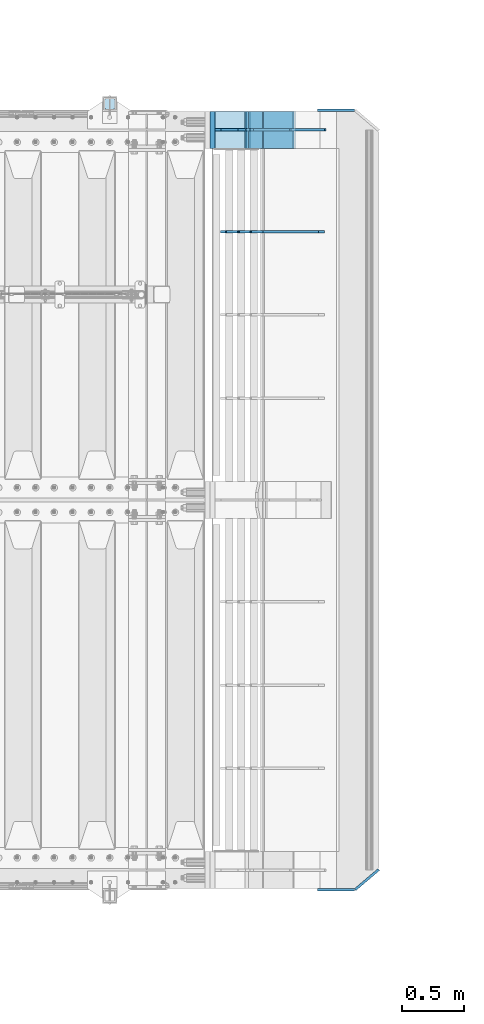
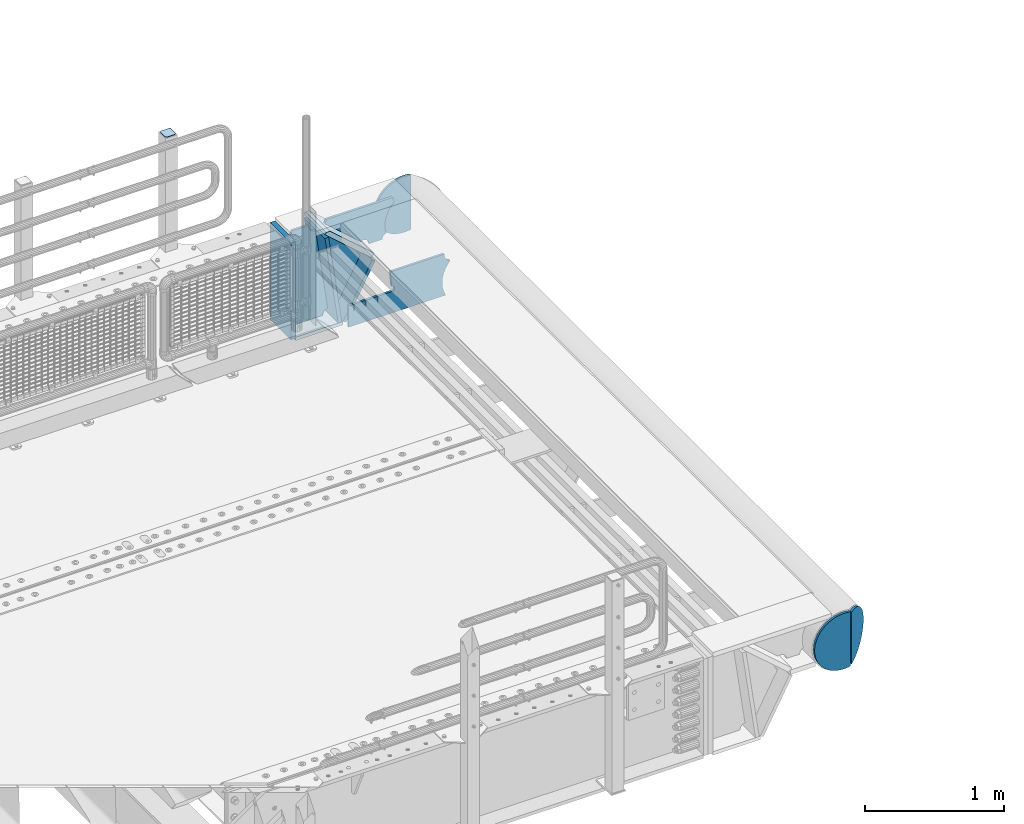
# One storey, part 180 of 193: 13 plates.
"""IFC2X3 building model written with IfcOpenShell, lengths in millimetres."""

from ifc_helpers import new_model, si_unit, frame, origin_with_axes, place, context, subcontext, project, spatial, faceted_brep, material, type_object, element, save


model = new_model("IFC2X3")

# Units and contexts
model_context = context("Model", 3, precision=1e-05, world=origin_with_axes())
body_context = subcontext(model_context, "Body", "Model", "MODEL_VIEW")
ifc_project = project(units=[si_unit("LENGTHUNIT", "METRE", prefix="MILLI"), si_unit("AREAUNIT", "SQUARE_METRE"), si_unit("VOLUMEUNIT", "CUBIC_METRE"), si_unit("MASSUNIT", "GRAM", prefix="KILO"), si_unit("TIMEUNIT", "SECOND"), si_unit("PLANEANGLEUNIT", "RADIAN"), si_unit("SOLIDANGLEUNIT", "STERADIAN"), si_unit("THERMODYNAMICTEMPERATUREUNIT", "DEGREE_CELSIUS"), si_unit("LUMINOUSINTENSITYUNIT", "LUMEN")], contexts=[model_context])

# Site, building, storey
site_placement = place(None, origin_with_axes())
site = spatial("IfcSite", under=ifc_project, at=site_placement, CompositionType="ELEMENT")
building_placement = place(site_placement, origin_with_axes())
building = spatial("IfcBuilding", under=site, at=building_placement, Name="Standard", CompositionType="ELEMENT")
storey_placement = place(building_placement, origin_with_axes())
storey = spatial("IfcBuildingStorey", under=building, at=storey_placement, Name="Undefined", CompositionType="ELEMENT", Elevation=0.0)

# Plates
ifc_material_1 = material(Name="STEEL/S355J2")
plate_type_1 = type_object("IfcPlateType", PredefinedType="NOTDEFINED")
plate_1_placement = place(storey_placement, frame((-29150.9999999999, 30166.0000000002, 1012.50000000001), z_axis=(0.0, 1.0, 0.0), x_axis=(-1.0, 0.0, 0.0)))
element("IfcPlate", 1, at=plate_1_placement, inside=storey, type_object=plate_type_1, material=ifc_material_1, context=body_context, shape_type="Brep", body=[
    faceted_brep([(0.0, -2.5, 19.0), (0.0, -2.5, 69.0), (0.0, 2.5, 69.0), (0.0, 2.5, 19.0), (0.476369668544066, -2.5, 73.2278977451715), (0.476369668544066, 2.5, 73.2278977451715), (1.88159150985302, -2.5, 77.2437910432345), (1.88159150985302, 2.5, 77.2437910432345), (4.14520183310742, -2.5, 80.8463062353148), (4.14520183310742, 2.5, 80.8463062353148), (7.15369376468516, -2.5, 83.8547981668926), (7.15369376468516, 2.5, 83.8547981668926), (10.7562089567655, -2.5, 86.118408490147), (10.7562089567655, 2.5, 86.118408490147), (14.7721022548285, -2.5, 87.5236303314559), (14.7721022548285, 2.5, 87.5236303314559), (19.0, -2.5, 88.0), (19.0, 2.5, 88.0), (69.0, -2.5, 88.0), (69.0, 2.5, 88.0), (73.2278977451715, -2.5, 87.5236303314559), (73.2278977451715, 2.5, 87.5236303314559), (77.2437910432345, -2.5, 86.118408490147), (77.2437910432345, 2.5, 86.118408490147), (80.8463062353148, -2.5, 83.8547981668926), (80.8463062353148, 2.5, 83.8547981668926), (83.8547981668926, -2.5, 80.8463062353148), (83.8547981668926, 2.5, 80.8463062353148), (86.118408490147, -2.5, 77.2437910432345), (86.118408490147, 2.5, 77.2437910432345), (87.5236303314559, -2.5, 73.2278977451715), (87.5236303314559, 2.5, 73.2278977451715), (88.0, -2.5, 69.0), (88.0, 2.5, 69.0), (88.0, -2.5, 19.0), (88.0, 2.5, 19.0), (87.5236303314559, -2.5, 14.7721022548285), (87.5236303314559, 2.5, 14.7721022548285), (86.118408490147, -2.5, 10.7562089567655), (86.118408490147, 2.5, 10.7562089567655), (83.8547981668926, -2.5, 7.15369376468516), (83.8547981668926, 2.5, 7.15369376468516), (80.8463062353148, -2.5, 4.14520183310742), (80.8463062353148, 2.5, 4.14520183310742), (77.2437910432345, -2.5, 1.88159150985302), (77.2437910432345, 2.5, 1.88159150985302), (73.2278977451715, -2.5, 0.476369668544066), (73.2278977451715, 2.5, 0.476369668544066), (69.0, -2.5, 0.0), (69.0, 2.5, 0.0), (19.0, -2.5, 0.0), (19.0, 2.5, 0.0), (14.7721022548285, -2.5, 0.476369668544066), (14.7721022548285, 2.5, 0.476369668544066), (10.7562089567655, -2.5, 1.88159150985302), (10.7562089567655, 2.5, 1.88159150985302), (7.15369376468516, -2.5, 4.14520183310742), (7.15369376468516, 2.5, 4.14520183310742), (4.14520183310742, -2.5, 7.15369376468516), (4.14520183310742, 2.5, 7.15369376468516), (1.88159150985302, -2.5, 10.7562089567655), (1.88159150985302, 2.5, 10.7562089567655), (0.476369668544066, -2.5, 14.7721022548285), (0.476369668544066, 2.5, 14.7721022548285)], [[[0, 1, 2, 3]], [[1, 4, 5, 2]], [[4, 6, 7, 5]], [[6, 8, 9, 7]], [[8, 10, 11, 9]], [[10, 12, 13, 11]], [[12, 14, 15, 13]], [[14, 16, 17, 15]], [[16, 18, 19, 17]], [[18, 20, 21, 19]], [[20, 22, 23, 21]], [[22, 24, 25, 23]], [[24, 26, 27, 25]], [[26, 28, 29, 27]], [[28, 30, 31, 29]], [[30, 32, 33, 31]], [[32, 34, 35, 33]], [[34, 36, 37, 35]], [[36, 38, 39, 37]], [[38, 40, 41, 39]], [[40, 42, 43, 41]], [[42, 44, 45, 43]], [[44, 46, 47, 45]], [[46, 48, 49, 47]], [[48, 50, 51, 49]], [[50, 52, 53, 51]], [[52, 54, 55, 53]], [[54, 56, 57, 55]], [[56, 58, 59, 57]], [[58, 60, 61, 59]], [[60, 62, 63, 61]], [[62, 0, 3, 63]], [[5, 7, 9, 11, 13, 15, 17, 19, 21, 23, 25, 27, 29, 31, 33, 35, 37, 39, 41, 43, 45, 47, 49, 51, 53, 55, 57, 59, 61, 63, 3, 2]], [[62, 60, 58, 56, 54, 52, 50, 48, 46, 44, 42, 40, 38, 36, 34, 32, 30, 28, 26, 24, 22, 20, 18, 16, 14, 12, 10, 8, 6, 4, 1, 0]]]),
])
ifc_material_2 = material(Name="STEEL/S355N")
plate_type_2 = type_object("IfcPlateType", PredefinedType="NOTDEFINED")
plate_2_placement = place(storey_placement, frame((-27701.0011701102, 30149.9999999992, -367.999999999302), z_axis=(-0.752989422949573, 0.0, 0.658032619955933), x_axis=(0.0, -1.0, 0.0)))
element("IfcPlate", 2, at=plate_2_placement, inside=storey, type_object=plate_type_2, material=ifc_material_2, context=body_context, shape_type="Brep", body=[
    faceted_brep([(-8.11269273981452e-10, 20.0, 490.766265601622), (0.0, -0.30381125094209, 514.0), (300.0, -0.30381125094209, 514.0), (300.0, 20.0, 490.766265601622), (300.0, -20.0, 0.0), (300.0, -20.0, 514.000000000004), (0.0, -20.0, 514.000000000004), (0.0, -20.0, 0.0), (0.0, 20.0, 0.0), (300.0, 20.0, 0.0)], [[[0, 1, 2, 3]], [[4, 5, 6, 7]], [[4, 7, 8, 9]], [[9, 8, 0, 3]], [[5, 4, 9, 3, 2]], [[6, 5, 2, 1]], [[8, 7, 6, 1, 0]]]),
])
ifc_material_3 = material()
plate_3_placement = place(storey_placement, frame((-28363.0011701094, 30150.0, -870.000000000003), z_axis=(0.0, 0.0, 1.0), x_axis=(0.0, -1.0, 0.0)))
element("IfcPlate", 3, at=plate_3_placement, inside=storey, type_object=plate_type_2, material=ifc_material_3, context=body_context, shape_type="Brep", body=[
    faceted_brep([(0.0, -20.0, 0.0), (0.0, -20.0, 850.0), (0.0, 20.0, 850.0), (0.0, 20.0, 0.0), (300.0, -20.0, 850.0), (300.0, 20.0, 850.0), (300.0, -20.0, 0.0), (300.0, 20.0, 0.0)], [[[0, 1, 2, 3]], [[1, 4, 5, 2]], [[4, 6, 7, 5]], [[6, 0, 3, 7]], [[5, 7, 3, 2]], [[6, 4, 1, 0]]]),
])
plate_type_3 = type_object("IfcPlateType", PredefinedType="NOTDEFINED")
plate_4_placement = place(storey_placement, frame((-27950.0011701109, 30150.0, -875.000000003253), z_axis=(0.0, -1.0, 0.0), x_axis=(-1.0, 0.0, 0.0)))
element("IfcPlate", 4, at=plate_4_placement, inside=storey, type_object=plate_type_3, material=ifc_material_2, context=body_context, shape_type="Brep", body=[
    faceted_brep([(0.0, -15.0, 0.0), (0.0, -15.0, 300.0), (0.0, 15.0, 300.0), (0.0, 15.0, 0.0), (393.0, -15.0, 300.0), (393.0, 15.0, 300.0), (393.0, -15.0, 0.0), (393.0, 15.0, 0.0)], [[[0, 1, 2, 3]], [[1, 4, 5, 2]], [[4, 6, 7, 5]], [[6, 0, 3, 7]], [[5, 7, 3, 2]], [[6, 4, 1, 0]]]),
])
plate_5_placement = place(storey_placement, frame((-27973.8519322781, 30150.000000001, -862.083788721732), z_axis=(-0.139173011053008, 0.0, 0.990268081377179), x_axis=(0.0, -1.0, 0.0)))
element("IfcPlate", 5, at=plate_5_placement, inside=storey, type_object=plate_type_3, material=ifc_material_2, context=body_context, shape_type="Brep", body=[
    faceted_brep([(1.00408215075731e-09, 14.9994702460535, -0.00376939767284057), (300.0, 15.0, 0.0), (300.0, -15.0, 4.21237841386892), (0.0, -15.0, 4.21237841386892), (0.0, -15.0, 792.0), (300.0, -15.0, 792.0), (300.0, 14.9999999999964, 792.0), (0.0, 14.9999999999964, 792.0)], [[[0, 1, 2, 3]], [[4, 5, 6, 7]], [[4, 7, 0, 3]], [[5, 4, 3, 2]], [[6, 5, 2, 1]], [[7, 6, 1, 0]]]),
])
plate_6_placement = place(storey_placement, frame((-27936.7531990434, 30150.000000001, -867.038754739308), z_axis=(0.469471552246176, 0.0, 0.882947598462992), x_axis=(0.0, -1.0, 0.0)))
element("IfcPlate", 6, at=plate_6_placement, inside=storey, type_object=plate_type_3, material=ifc_material_2, context=body_context, shape_type="Brep", body=[
    faceted_brep([(0.0, -15.0, 0.0), (0.0, -15.0000000000036, 514.999999999996), (0.0, 14.9999999999964, 514.999999999998), (0.0, 15.0, 0.0), (300.0, -15.0000000000036, 514.999999999996), (300.0, 14.9999999999964, 514.999999999998), (300.0, -15.0, 0.0), (300.0, 15.0, 0.0)], [[[0, 1, 2, 3]], [[1, 4, 5, 2]], [[4, 6, 7, 5]], [[6, 0, 3, 7]], [[5, 7, 3, 2]], [[6, 4, 1, 0]]]),
])
plate_type_4 = type_object("IfcPlateType", PredefinedType="NOTDEFINED")
plate_7_placement = place(storey_placement, frame((-27386.0011701102, 29999.9999999994, -29.9999999993023), z_axis=(-0.000446694000102124, 0.0, -0.99999990023223), x_axis=(-0.99999990023223, 0.0, 0.000446694000103734)))
element("IfcPlate", 7, at=plate_7_placement, inside=storey, type_object=plate_type_4, material=ifc_material_2, context=body_context, shape_type="Brep", body=[
    faceted_brep([(125.007775472983, 10.0, 291.842314882031), (131.755016800053, 10.0, 263.793234614468), (131.755016800053, -10.0, 263.793234614468), (125.007775472983, -10.0, 291.842314882031), (134.899927074483, 10.0, 224.060281342732), (134.899927074483, -10.0, 224.060281342732), (131.79051499522, 10.0, 184.324534302446), (131.79051499522, -10.0, 184.324534302446), (122.503344607208, 10.0, 145.564419461128), (122.503344607208, -10.0, 145.564419461128), (107.267096867745, 10.0, 108.734339483615), (107.267096867745, -10.0, 108.734339483615), (86.4569387623887, 10.0, 74.7411731709829), (86.4569387623887, -10.0, 74.7411731709829), (60.5852854486511, 10.0, 44.4219450946983), (60.5852854486511, -10.0, 44.4219450946983), (56.2519855253086, 10.0, 40.7176084148888), (56.2519855253086, -10.0, 40.7176084148888), (136.409234539125, -10.0, 297.721677540594), (147.386991180581, -10.0, 308.778803581017), (147.386991180581, 10.0, 308.778803581017), (136.409234539125, 10.0, 297.721677540594), (154.428166132755, -10.0, 322.678193223937), (154.428166132755, 10.0, 322.678193223937), (156.849001662977, -10.0, 338.070097995228), (156.849001662977, 10.0, 338.070097995228), (264.849004013293, -10.0, 338.118348049693), (264.849004013293, 10.0, 338.118348049693), (267.62876711955, -10.0, 321.701412969031), (267.62876711955, 10.0, 321.701412969031), (275.645118712178, -10.0, 307.107546191754), (275.645118712178, 10.0, 307.107546191754), (288.009068357209, -10.0, 295.955165748785), (288.009068357209, 10.0, 295.955165748785), (303.34948944753, -10.0, 289.481038692482), (303.34948944753, 10.0, 289.481038692482), (319.965173216926, -10.0, 288.403127172445), (319.965173216926, 10.0, 288.403127172445), (336.013487920231, -10.0, 292.840968489265), (336.013487920231, 10.0, 292.840968489265), (335.869079589844, -10.0, 293.150054931641), (335.869079589844, 10.0, 293.150054931641), (633.937057436444, -10.0, 32.8861672876965), (633.937057436444, 10.0, 32.8861672876965), (628.672097726401, -10.0, 25.6357574923157), (628.672097726401, 10.0, 25.6357574923157), (624.785781531271, -10.0, 17.5620477266102), (624.785781531271, 10.0, 17.5620477266102), (622.402919050601, -10.0, 8.92432757904926), (622.402919050601, 10.0, 8.92432757904926), (621.600036621097, -10.0, -8.74671002293326e-10), (621.600036621097, 10.0, -8.74671002293326e-10), (70.0, -10.0, -9.84954340310651e-11), (70.0, 10.0, -9.84954340310651e-11), (67.7728137216618, -10.0, 17.5170123094482), (67.7728137216618, 10.0, 17.5170123094482), (61.2329794213983, -10.0, 33.9193489203215), (61.2329794213983, 10.0, 33.9193489203215)], [[[0, 1, 2, 3]], [[4, 5, 2, 1]], [[6, 7, 5, 4]], [[8, 9, 7, 6]], [[10, 11, 9, 8]], [[12, 13, 11, 10]], [[14, 15, 13, 12]], [[16, 17, 15, 14]], [[18, 19, 20, 21]], [[19, 22, 23, 20]], [[22, 24, 25, 23]], [[24, 26, 27, 25]], [[26, 28, 29, 27]], [[28, 30, 31, 29]], [[30, 32, 33, 31]], [[32, 34, 35, 33]], [[34, 36, 37, 35]], [[36, 38, 39, 37]], [[38, 40, 41, 39]], [[40, 42, 43, 41]], [[42, 44, 45, 43]], [[44, 46, 47, 45]], [[46, 48, 49, 47]], [[48, 50, 51, 49]], [[50, 52, 53, 51]], [[52, 54, 55, 53]], [[54, 56, 57, 55]], [[12, 10, 8, 6, 4, 1, 0, 21, 20, 23, 25, 27, 29, 31, 33, 35, 37, 39, 41, 43, 45, 47, 49, 51, 53, 55, 57, 16, 14]], [[18, 21, 0, 3]], [[56, 54, 52, 50, 48, 46, 44, 42, 40, 38, 36, 34, 32, 30, 28, 26, 24, 22, 19, 18, 3, 2, 5, 7, 9, 11, 13, 15, 17]], [[57, 56, 17, 16]]]),
])
plate_type_5 = type_object("IfcPlateType", PredefinedType="NOTDEFINED")
plate_8_placement = place(storey_placement, frame((-27701.9974314966, 30000.000000001, -393.996688204407), z_axis=(-0.658066357015091, 0.0, -0.752959939017267), x_axis=(-0.752959939017268, 0.0, 0.65806635701509)))
element("IfcPlate", 8, at=plate_8_placement, inside=storey, type_object=plate_type_5, material=ifc_material_2, context=body_context, shape_type="Brep", body=[
    faceted_brep([(-11.3595226159632, -10.0, 48.6925173505915), (-112.015767301036, -10.0, 480.154833723627), (-112.015767301036, 10.0, 480.154833723627), (-11.3595226159632, 10.0, 48.6925173505915), (-104.567323293642, -10.0, 482.519601382541), (-104.567323293642, 10.0, 482.519601382541), (-97.5783311599989, -10.0, 486.016090073754), (-97.5783311599989, 10.0, 486.016090073754), (-91.2195220373869, -10.0, 490.558885551654), (-91.2195220373869, 10.0, 490.558885551654), (-85.6462325884277, -10.0, 496.037013784004), (-85.6462325884277, 10.0, 496.037013784004), (447.024482710491, -10.0, 32.810337289633), (447.024482710491, 10.0, 32.810337289633), (441.786973010392, -10.0, 25.5709623937255), (441.786973010392, 10.0, 25.5709623937255), (437.921644570128, -10.0, 17.5149526624118), (437.921644570128, 10.0, 17.5149526624118), (435.551940606492, -10.0, 8.89958500531793), (435.551940606492, 10.0, 8.89958500531793), (434.753540039059, -10.0, -5.20230969414115e-10), (434.753540039059, 10.0, -5.20230969414115e-10), (50.0, -10.0, 0.0), (50.0, 10.0, 0.0), (47.7668538974212, -10.0, 14.7759151575156), (47.7668538974212, 10.0, 14.7759151575156), (41.2668932502784, -10.0, 28.2319592212407), (41.2668932502784, 10.0, 28.2319592212407), (31.0807325300157, -10.0, 39.1661596968261), (31.0807325300157, 10.0, 39.1661596968261), (18.1182591411452, -10.0, 46.6018098971945), (18.1182591411452, 10.0, 46.6018098971945), (3.53735696080548, -10.0, 49.8747140917294), (3.53735696080548, 10.0, 49.8747140917294)], [[[0, 1, 2, 3]], [[1, 4, 5, 2]], [[4, 6, 7, 5]], [[6, 8, 9, 7]], [[8, 10, 11, 9]], [[10, 12, 13, 11]], [[12, 14, 15, 13]], [[14, 16, 17, 15]], [[16, 18, 19, 17]], [[18, 20, 21, 19]], [[20, 22, 23, 21]], [[22, 24, 25, 23]], [[24, 26, 27, 25]], [[26, 28, 29, 27]], [[28, 30, 31, 29]], [[30, 32, 33, 31]], [[32, 0, 3, 33]], [[5, 7, 9, 11, 13, 15, 17, 19, 21, 23, 25, 27, 29, 31, 33, 3, 2]], [[32, 30, 28, 26, 24, 22, 20, 18, 16, 14, 12, 10, 8, 6, 4, 1, 0]]]),
])
plate_type_6 = type_object("IfcPlateType", PredefinedType="NOTDEFINED")
plate_9_placement = place(storey_placement, frame((-28104.001170111, 30000.0, -30.0000000032531), z_axis=(0.0, 0.0, -1.0), x_axis=(-1.0, 0.0, 0.0)))
element("IfcPlate", 9, at=plate_9_placement, inside=storey, type_object=plate_type_6, material=ifc_material_2, context=body_context, shape_type="Brep", body=[
    faceted_brep([(-9.00602409638668, -10.0, 65.0), (-108.137843376921, -10.0, 780.473130459514), (-108.137843376921, 10.0, 780.473130459514), (-9.00602409638668, 10.0, 65.0), (-94.4157884488377, -10.0, 784.433672138112), (-94.4157884488377, 10.0, 784.433672138112), (-82.3732461236723, -10.0, 792.112074067144), (-82.3732461236723, 10.0, 792.112074067144), (-72.9927947992364, -10.0, 802.881837982249), (-72.9927947992364, 10.0, 802.881837982249), (-67.0398068183713, -10.0, 815.864234368775), (-67.0398068183713, 10.0, 815.864234368775), (-65.0, -10.0, 830.0), (-65.0, 10.0, 830.0), (189.0, -10.0, 830.0), (189.0, 10.0, 830.0), (191.447174185243, -10.0, 814.549150281253), (191.447174185243, 10.0, 814.549150281253), (198.549150281251, -10.0, 800.610737385376), (198.549150281251, 10.0, 800.610737385376), (209.610737385377, -10.0, 789.549150281253), (209.610737385377, 10.0, 789.549150281253), (223.549150281251, -10.0, 782.447174185242), (223.549150281251, 10.0, 782.447174185242), (239.0, -10.0, 780.0), (239.0, 10.0, 780.0), (239.0, -10.0, 50.0), (239.0, 10.0, 50.0), (223.549150281251, -10.0, 47.5528258147577), (223.549150281251, 10.0, 47.5528258147577), (209.610737385377, -10.0, 40.4508497187474), (209.610737385377, 10.0, 40.4508497187474), (198.549150281251, -10.0, 29.3892626146237), (198.549150281251, 10.0, 29.3892626146237), (191.447174185243, -10.0, 15.4508497187474), (191.447174185243, 10.0, 15.4508497187474), (189.0, -10.0, 0.0), (189.0, 10.0, 0.0), (50.4776502774184, -10.0, 0.0), (50.4776502774184, 10.0, 0.0), (47.3830020671812, -10.0, 22.3352870825933), (47.3830020671812, 10.0, 22.3352870825933), (42.8384615202776, -10.0, 37.3040735979326), (42.8384615202776, 10.0, 37.3040735979326), (33.8907372011709, -10.0, 50.1358952937587), (33.8907372011709, 10.0, 50.1358952937587), (21.4156947086703, -10.0, 59.5746840579253), (21.4156947086703, 10.0, 59.5746840579253), (6.63447812067898, -10.0, 64.6965054822873), (6.63447812067898, 10.0, 64.6965054822873)], [[[0, 1, 2, 3]], [[1, 4, 5, 2]], [[4, 6, 7, 5]], [[6, 8, 9, 7]], [[8, 10, 11, 9]], [[10, 12, 13, 11]], [[12, 14, 15, 13]], [[14, 16, 17, 15]], [[16, 18, 19, 17]], [[18, 20, 21, 19]], [[20, 22, 23, 21]], [[22, 24, 25, 23]], [[24, 26, 27, 25]], [[26, 28, 29, 27]], [[28, 30, 31, 29]], [[30, 32, 33, 31]], [[32, 34, 35, 33]], [[34, 36, 37, 35]], [[36, 38, 39, 37]], [[38, 40, 41, 39]], [[40, 42, 43, 41]], [[42, 44, 45, 43]], [[44, 46, 47, 45]], [[46, 48, 49, 47]], [[48, 0, 3, 49]], [[5, 7, 9, 11, 13, 15, 17, 19, 21, 23, 25, 27, 29, 31, 33, 35, 37, 39, 41, 43, 45, 47, 49, 3, 2]], [[48, 46, 44, 42, 40, 38, 36, 34, 32, 30, 28, 26, 24, 22, 20, 18, 16, 14, 12, 10, 8, 6, 4, 1, 0]]]),
])
plate_type_7 = type_object("IfcPlateType", PredefinedType="NOTDEFINED")
plate_10_placement = place(storey_placement, frame((-27457.0817660324, 29174.9992828369, -374.002067436516), z_axis=(0.0, 0.0, 1.0), x_axis=(-1.0, 0.0, 0.0)))
element("IfcPlate", 10, at=plate_10_placement, inside=storey, type_object=plate_type_7, material=ifc_material_2, context=body_context, shape_type="Brep", body=[
    faceted_brep([(801.919404066546, -10.0, 188.0), (801.919404066546, 10.0, 188.0), (801.919404066546, 10.0, 132.002067436952), (801.919404066546, -10.0, 132.002067436952), (793.919404066546, 10.0, 132.002067436952), (793.919404066546, -10.0, 132.002067436952), (793.919404066546, 10.0, 180.002067436952), (793.919404066546, -10.0, 180.002067436952), (793.527856196906, 10.0, 182.474203391951), (793.527856196906, -10.0, 182.474203391951), (792.391540021545, 10.0, 184.704349455291), (792.391540021545, -10.0, 184.704349455291), (790.621686084887, 10.0, 186.474203391951), (790.621686084887, -10.0, 186.474203391951), (788.391540021545, 10.0, 187.610519567313), (788.391540021545, -10.0, 187.610519567313), (785.919404066546, -10.0, 188.002067436952), (785.919404066546, 10.0, 188.0), (841.0, -10.0, 188.0), (841.0, -10.0, 0.0), (841.0, 10.0, 0.0), (841.0, 10.0, 188.0), (33.3619566736015, -10.0, 0.0), (33.3619566736015, 10.0, 0.0), (36.2350612208174, -10.0, 4.68848050267007), (36.2350612208174, 10.0, 4.68848050267007), (51.4877592159428, -10.0, 41.5117508652783), (51.4877592159428, 10.0, 41.5117508652783), (60.792242588137, -10.0, 80.2677133162963), (60.792242588137, 10.0, 80.2677133162963), (63.9194040769726, -10.0, 120.002067436515), (63.9194040769726, 10.0, 120.002067436515), (60.792242588137, -10.0, 159.736421556734), (60.792242588137, 10.0, 159.736421556734), (51.4877592159428, -10.0, 198.492384007752), (51.4877592159428, 10.0, 198.492384007752), (36.2350612208174, -10.0, 235.31565437036), (36.2350612208174, 10.0, 235.31565437036), (15.4097206482074, -10.0, 269.299521518803), (15.4097206482074, 10.0, 269.299521518803), (-3.35474438098754, -10.0, 291.269887256574), (-3.35474438098754, 10.0, 291.269887256574), (-2.36881039375294, -10.0, 291.426043859339), (-2.36881039375294, 10.0, 291.426043859339), (17.1449676604716, -10.0, 301.368810393754), (17.1449676604716, 10.0, 301.368810393754), (32.6311896062471, -10.0, 316.855032339527), (32.6311896062471, 10.0, 316.855032339527), (42.573956140659, -10.0, 336.368810393754), (42.573956140659, 10.0, 336.368810393754), (46.0, -10.0, 358.0), (46.0, 10.0, 358.0), (45.0495205499137, -10.0, 364.001091067617), (45.0495205499137, 10.0, 364.001091067617), (495.040008544922, -10.0, 364.010009765625), (495.040008544922, 10.0, 364.010009765625), (483.600036621094, -10.0, 233.759994506836), (483.600036621094, 10.0, 233.759994506836), (472.0, -10.0, 233.759994506836), (472.0, 10.0, 233.759994506836), (468.909830056251, -10.0, 233.270559669787), (468.909830056251, 10.0, 233.270559669787), (466.122147477075, -10.0, 231.850164450585), (466.122147477075, 10.0, 231.850164450585), (463.909830056251, -10.0, 229.637847029761), (463.909830056251, 10.0, 229.637847029761), (462.489434837047, -10.0, 226.850164450585), (462.489434837047, 10.0, 226.850164450585), (462.0, -10.0, 223.759994506836), (462.0, 10.0, 223.759994506836), (462.0, -10.0, 198.0), (462.0, 10.0, 198.0), (462.489434837047, -10.0, 194.909830056251), (462.489434837047, 10.0, 194.909830056251), (463.909830056251, -10.0, 192.122147477075), (463.909830056251, 10.0, 192.122147477075), (466.122147477075, -10.0, 189.909830056251), (466.122147477075, 10.0, 189.909830056251), (468.909830056251, -10.0, 188.489434837048), (468.909830056251, 10.0, 188.489434837048), (472.0, -10.0, 188.0), (472.0, 10.0, 188.0), (585.919404066546, -10.0, 188.002067436952), (585.919404066546, 10.0, 188.0), (588.391540021545, -10.0, 187.610519567313), (588.391540021545, 10.0, 187.610519567313), (590.621686084887, -10.0, 186.474203391951), (590.621686084887, 10.0, 186.474203391951), (592.391540021545, -10.0, 184.704349455291), (592.391540021545, 10.0, 184.704349455291), (593.527856196906, -10.0, 182.474203391951), (593.527856196906, 10.0, 182.474203391951), (593.919404066546, -10.0, 180.002067436952), (593.919404066546, 10.0, 180.002067436952), (593.919404066546, -10.0, 132.002067436952), (593.919404066546, 10.0, 132.002067436952), (601.919404066546, -10.0, 132.002067436952), (601.919404066546, 10.0, 132.002067436952), (601.919404066546, -10.0, 188.0), (601.919404066546, 10.0, 188.0), (685.919404066546, -10.0, 188.002067436952), (685.919404066546, 10.0, 188.0), (688.391540021545, -10.0, 187.610519567313), (688.391540021545, 10.0, 187.610519567313), (690.621686084887, -10.0, 186.474203391951), (690.621686084887, 10.0, 186.474203391951), (692.391540021545, -10.0, 184.704349455291), (692.391540021545, 10.0, 184.704349455291), (693.527856196906, -10.0, 182.474203391951), (693.527856196906, 10.0, 182.474203391951), (693.919404066546, -10.0, 180.002067436952), (693.919404066546, 10.0, 180.002067436952), (693.919404066546, -10.0, 132.002067436952), (693.919404066546, 10.0, 132.002067436952), (701.919404066546, -10.0, 132.002067436952), (701.919404066546, 10.0, 132.002067436952), (701.919404066546, -10.0, 188.0), (701.919404066546, 10.0, 188.0)], [[[0, 1, 2, 3]], [[3, 2, 4, 5]], [[5, 4, 6, 7]], [[7, 6, 8, 9]], [[9, 8, 10, 11]], [[11, 10, 12, 13]], [[13, 12, 14, 15]], [[16, 15, 14, 17]], [[18, 19, 20, 21]], [[20, 19, 22, 23]], [[22, 24, 25, 23]], [[26, 27, 25, 24]], [[28, 29, 27, 26]], [[30, 31, 29, 28]], [[32, 33, 31, 30]], [[34, 35, 33, 32]], [[36, 37, 35, 34]], [[38, 39, 37, 36]], [[39, 38, 40, 41]], [[40, 42, 43, 41]], [[44, 45, 43, 42]], [[46, 47, 45, 44]], [[48, 49, 47, 46]], [[50, 51, 49, 48]], [[52, 53, 51, 50]], [[54, 55, 53, 52]], [[54, 56, 57, 55]], [[56, 58, 59, 57]], [[58, 60, 61, 59]], [[60, 62, 63, 61]], [[62, 64, 65, 63]], [[64, 66, 67, 65]], [[66, 68, 69, 67]], [[68, 70, 71, 69]], [[70, 72, 73, 71]], [[72, 74, 75, 73]], [[74, 76, 77, 75]], [[76, 78, 79, 77]], [[78, 80, 81, 79]], [[81, 80, 82, 83]], [[82, 84, 85, 83]], [[86, 87, 85, 84]], [[88, 89, 87, 86]], [[90, 91, 89, 88]], [[92, 93, 91, 90]], [[94, 95, 93, 92]], [[96, 97, 95, 94]], [[98, 99, 97, 96]], [[99, 98, 100, 101]], [[100, 102, 103, 101]], [[104, 105, 103, 102]], [[106, 107, 105, 104]], [[108, 109, 107, 106]], [[110, 111, 109, 108]], [[112, 113, 111, 110]], [[114, 115, 113, 112]], [[116, 117, 115, 114]], [[117, 116, 16, 17]], [[12, 10, 8, 6, 4, 2, 1, 21, 20, 23, 25, 27, 29, 31, 33, 35, 37, 39, 41, 43, 45, 47, 49, 51, 53, 55, 57, 59, 61, 63, 65, 67, 69, 71, 73, 75, 77, 79, 81, 83, 85, 87, 89, 91, 93, 95, 97, 99, 101, 103, 105, 107, 109, 111, 113, 115, 117, 17, 14]], [[18, 21, 1, 0]], [[116, 114, 112, 110, 108, 106, 104, 102, 100, 98, 96, 94, 92, 90, 88, 86, 84, 82, 80, 78, 76, 74, 72, 70, 68, 66, 64, 62, 60, 58, 56, 54, 52, 50, 48, 46, 44, 42, 40, 38, 36, 34, 32, 30, 28, 26, 24, 22, 19, 18, 0, 3, 5, 7, 9, 11, 13, 15, 16]]]),
])
plate_type_8 = type_object("IfcPlateType", PredefinedType="NOTDEFINED")
plate_11_placement = place(storey_placement, frame((-27023.0011701094, 30160.0, -498.000000000001), z_axis=(0.0, 0.0, 1.0), x_axis=(-1.0, 0.0, 0.0)))
element("IfcPlate", 11, at=plate_11_placement, inside=storey, type_object=plate_type_8, material=ifc_material_2, context=body_context, shape_type="Brep", body=[
    faceted_brep([(244.0, -10.0, 0.0), (209.275179461318, -10.0, 2.48356818105242), (209.275179461318, 10.0, 2.48356818105242), (244.0, 10.0, 0.0), (278.724820538682, -10.0, 2.48356818105236), (278.724820538682, 10.0, 2.48356818105236), (312.742743869308, -10.0, 9.88371443806261), (312.742743869308, 10.0, 9.88371443806261), (345.361263172461, -10.0, 22.0497931334975), (345.361263172461, 10.0, 22.0497931334975), (375.916359459166, -10.0, 38.7341379891918), (375.916359459166, 10.0, 38.7341379891918), (403.78601908265, -10.0, 59.597103857561), (403.78601908265, 10.0, 59.597103857561), (428.402896142437, -10.0, 84.2139809173505), (428.402896142437, 10.0, 84.2139809173505), (449.265862010809, -10.0, 112.083640540834), (449.265862010809, 10.0, 112.083640540834), (465.950206866502, -10.0, 142.63873682754), (465.950206866502, 10.0, 142.63873682754), (478.116285561937, -10.0, 175.257256130691), (478.116285561937, 10.0, 175.257256130691), (485.516431818949, -10.0, 209.275179461318), (485.516431818949, 10.0, 209.275179461318), (488.0, -10.0, 244.0), (488.0, 10.0, 244.0), (485.516431818949, -10.0, 278.724820538682), (485.516431818949, 10.0, 278.724820538682), (478.116285561937, -10.0, 312.742743869309), (478.116285561937, 10.0, 312.742743869309), (465.950206866502, -10.0, 345.36126317246), (465.950206866502, 10.0, 345.36126317246), (449.265862010809, -10.0, 375.916359459166), (449.265862010809, 10.0, 375.916359459166), (428.402896142437, -10.0, 403.78601908265), (428.402896142437, 10.0, 403.78601908265), (403.78601908265, -10.0, 428.402896142439), (403.78601908265, 10.0, 428.402896142439), (375.916359459166, -10.0, 449.265862010808), (375.916359459166, 10.0, 449.265862010808), (345.361263172461, -10.0, 465.950206866503), (345.361263172461, 10.0, 465.950206866503), (312.742743869308, -10.0, 478.116285561937), (312.742743869308, 10.0, 478.116285561937), (278.724820538682, -10.0, 485.516431818948), (278.724820538682, 10.0, 485.516431818948), (244.0, -10.0, 488.0), (244.0, 10.0, 488.0), (209.275179461318, -10.0, 485.516431818948), (209.275179461318, 10.0, 485.516431818948), (190.055415081213, -10.0, 481.335427997647), (190.058547913366, -10.0, 6.66389049643317), (190.053997906714, 10.0, 6.66488028979495), (190.050865087629, 10.0, 481.334438207128)], [[[0, 1, 2, 3]], [[4, 0, 3, 5]], [[6, 4, 5, 7]], [[8, 6, 7, 9]], [[10, 8, 9, 11]], [[12, 10, 11, 13]], [[14, 12, 13, 15]], [[16, 14, 15, 17]], [[18, 16, 17, 19]], [[20, 18, 19, 21]], [[22, 20, 21, 23]], [[24, 22, 23, 25]], [[26, 24, 25, 27]], [[28, 26, 27, 29]], [[30, 28, 29, 31]], [[32, 30, 31, 33]], [[34, 32, 33, 35]], [[36, 34, 35, 37]], [[38, 36, 37, 39]], [[40, 38, 39, 41]], [[42, 40, 41, 43]], [[44, 42, 43, 45]], [[46, 44, 45, 47]], [[48, 46, 47, 49]], [[1, 0, 4, 6, 8, 10, 12, 14, 16, 18, 20, 22, 24, 26, 28, 30, 32, 34, 36, 38, 40, 42, 44, 46, 48, 50, 51]], [[2, 1, 51, 52]], [[49, 47, 45, 43, 41, 39, 37, 35, 33, 31, 29, 27, 25, 23, 21, 19, 17, 15, 13, 11, 9, 7, 5, 3, 2, 52, 53]], [[48, 49, 53, 50]], [[52, 51, 50, 53]]]),
])
plate_12_placement = place(storey_placement, frame((-27022.9974739935, 23840.0, -498.0), z_axis=(0.0, 0.0, 1.0), x_axis=(-1.0, 0.0, 0.0)))
element("IfcPlate", 12, at=plate_12_placement, inside=storey, type_object=plate_type_8, material=ifc_material_2, context=body_context, shape_type="Brep", body=[
    faceted_brep([(244.0, -10.0, 0.0), (209.275179461318, -10.0, 2.48356818105242), (209.275179461318, 10.0, 2.48356818105242), (244.0, 10.0, 0.0), (278.724820538682, -10.0, 2.48356818105236), (278.724820538682, 10.0, 2.48356818105236), (312.742743869308, -10.0, 9.88371443806261), (312.742743869308, 10.0, 9.88371443806261), (345.361263172461, -10.0, 22.0497931334975), (345.361263172461, 10.0, 22.0497931334975), (375.916359459166, -10.0, 38.7341379891918), (375.916359459166, 10.0, 38.7341379891918), (403.78601908265, -10.0, 59.597103857561), (403.78601908265, 10.0, 59.597103857561), (428.402896142437, -10.0, 84.2139809173505), (428.402896142437, 10.0, 84.2139809173505), (449.265862010809, -10.0, 112.083640540834), (449.265862010809, 10.0, 112.083640540834), (465.950206866502, -10.0, 142.63873682754), (465.950206866502, 10.0, 142.63873682754), (478.116285561937, -10.0, 175.257256130691), (478.116285561937, 10.0, 175.257256130691), (485.516431818949, -10.0, 209.275179461318), (485.516431818949, 10.0, 209.275179461318), (488.0, -10.0, 244.0), (488.0, 10.0, 244.0), (485.516431818949, -10.0, 278.724820538682), (485.516431818949, 10.0, 278.724820538682), (478.116285561937, -10.0, 312.742743869309), (478.116285561937, 10.0, 312.742743869309), (465.950206866502, -10.0, 345.36126317246), (465.950206866502, 10.0, 345.36126317246), (449.265862010809, -10.0, 375.916359459166), (449.265862010809, 10.0, 375.916359459166), (428.402896142437, -10.0, 403.78601908265), (428.402896142437, 10.0, 403.78601908265), (403.78601908265, -10.0, 428.402896142439), (403.78601908265, 10.0, 428.402896142439), (375.916359459166, -10.0, 449.265862010808), (375.916359459166, 10.0, 449.265862010808), (345.361263172461, -10.0, 465.950206866503), (345.361263172461, 10.0, 465.950206866503), (312.742743869308, -10.0, 478.116285561937), (312.742743869308, 10.0, 478.116285561937), (278.724820538682, -10.0, 485.516431818948), (278.724820538682, 10.0, 485.516431818948), (244.0, -10.0, 488.0), (244.0, 10.0, 488.0), (209.275179461318, -10.0, 485.516431818948), (209.275179461318, 10.0, 485.516431818948), (189.372062160266, -10.0, 481.186773668839), (189.375193030173, -10.0, 6.81254525210147), (189.379743036825, 10.0, 6.81155545873969), (189.376612153854, 10.0, 481.187763459359)], [[[0, 1, 2, 3]], [[4, 0, 3, 5]], [[6, 4, 5, 7]], [[8, 6, 7, 9]], [[10, 8, 9, 11]], [[12, 10, 11, 13]], [[14, 12, 13, 15]], [[16, 14, 15, 17]], [[18, 16, 17, 19]], [[20, 18, 19, 21]], [[22, 20, 21, 23]], [[24, 22, 23, 25]], [[26, 24, 25, 27]], [[28, 26, 27, 29]], [[30, 28, 29, 31]], [[32, 30, 31, 33]], [[34, 32, 33, 35]], [[36, 34, 35, 37]], [[38, 36, 37, 39]], [[40, 38, 39, 41]], [[42, 40, 41, 43]], [[44, 42, 43, 45]], [[46, 44, 45, 47]], [[48, 46, 47, 49]], [[1, 0, 4, 6, 8, 10, 12, 14, 16, 18, 20, 22, 24, 26, 28, 30, 32, 34, 36, 38, 40, 42, 44, 46, 48, 50, 51]], [[2, 1, 51, 52]], [[49, 47, 45, 43, 41, 39, 37, 35, 33, 31, 29, 27, 25, 23, 21, 19, 17, 15, 13, 11, 9, 7, 5, 3, 2, 52, 53]], [[48, 49, 53, 50]], [[52, 51, 50, 53]]]),
])
plate_type_9 = type_object("IfcPlateType", PredefinedType="NOTDEFINED")
plate_13_placement = place(storey_placement, frame((-27169.328144425, 23874.0507479925, -30.6102092804237), z_axis=(-0.0672019629768904, -0.0573522459802765, -0.996089662657469), x_axis=(-0.758955820878059, -0.645120692896345, 0.0883479119858046)))
element("IfcPlate", 13, at=plate_13_placement, inside=storey, type_object=plate_type_9, material=ifc_material_2, context=body_context, shape_type="Brep", body=[
    faceted_brep([(0.0, -10.0, 0.0), (-48.0487670880657, -10.0, 8.6701745986939), (-48.048767088063, 10.0, 8.67017459869408), (0.0, 10.0, 0.0), (-93.1333465523521, -9.99999999999272, 25.6771621704106), (-93.1333465523539, 10.0, 25.6771621704106), (-133.522018422303, -10.0, 50.3669776916506), (-133.5220184223, 10.0, 50.3669776916507), (-167.658004743993, -10.0, 81.7919921875005), (-167.65800474399, 10.0, 81.7919921875006), (-194.131179785254, -10.0, 118.752670288086), (-194.131179785255, 10.0, 118.752670288086), (-212.241073575678, -10.0, 159.800354003906), (-212.241073575679, 10.0, 159.800354003906), (-220.965927082378, -9.99999999999272, 203.387512207032), (-220.965927082379, 10.0, 203.387512207032), (-220.078811594765, -10.0, 247.828140258789), (-220.078811594767, 10.0, 247.828140258789), (-209.490798890527, -10.0, 291.426422119141), (-209.490798890525, 10.0, 291.426422119141), (-189.979858330364, -10.0, 332.473327636719), (-189.979858330365, 10.0, 332.473327636719), (-161.934860153855, -10.0, 369.423980712891), (-161.934860153856, 9.99999999999272, 369.423980712891), (-126.533912576622, -9.99999999999272, 400.848876953125), (-126.53391257662, 10.0, 400.848876953125), (-85.1552428327968, -10.0, 425.539093017578), (-85.1552428327941, 10.0000000000073, 425.539093017578), (-39.3886450815107, -10.0, 442.546478271485), (-39.3886450815126, 10.0, 442.546478271485), (8.99617299735201, -10.0, 451.215240478516), (8.9961729973511, 10.0, 451.215240478516), (49.1690940856997, -10.0, 2.21120899368543e-11), (49.169094085697, 9.99999999999272, 2.18278728425503e-11)], [[[0, 1, 2, 3]], [[1, 4, 5, 2]], [[4, 6, 7, 5]], [[6, 8, 9, 7]], [[8, 10, 11, 9]], [[10, 12, 13, 11]], [[12, 14, 15, 13]], [[14, 16, 17, 15]], [[16, 18, 19, 17]], [[18, 20, 21, 19]], [[20, 22, 23, 21]], [[22, 24, 25, 23]], [[24, 26, 27, 25]], [[26, 28, 29, 27]], [[28, 30, 31, 29]], [[30, 32, 33, 31]], [[32, 0, 3, 33]], [[5, 7, 9, 11, 13, 15, 17, 19, 21, 23, 25, 27, 29, 31, 33, 3, 2]], [[32, 30, 28, 26, 24, 22, 20, 18, 16, 14, 12, 10, 8, 6, 4, 1, 0]]]),
])

save(model, "model.ifc")
